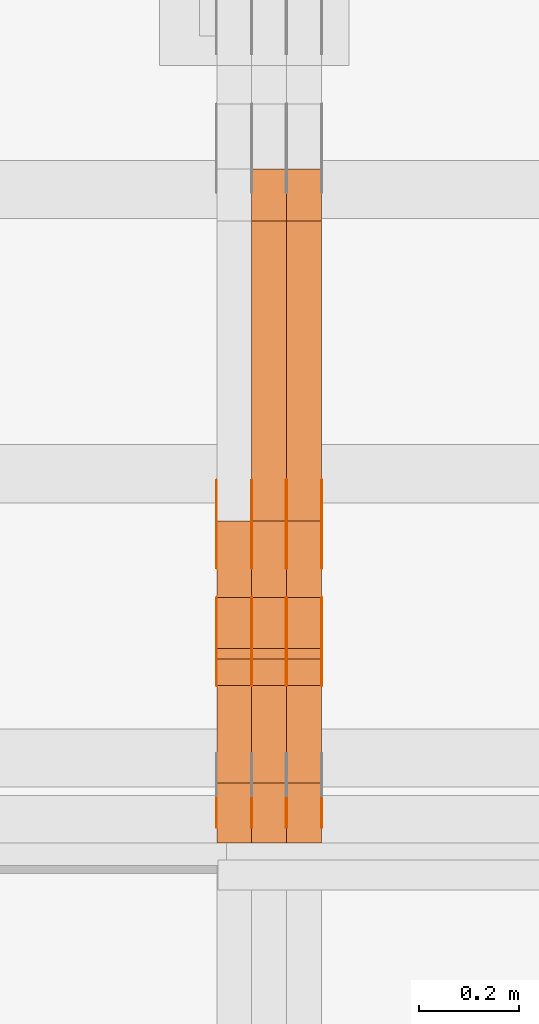
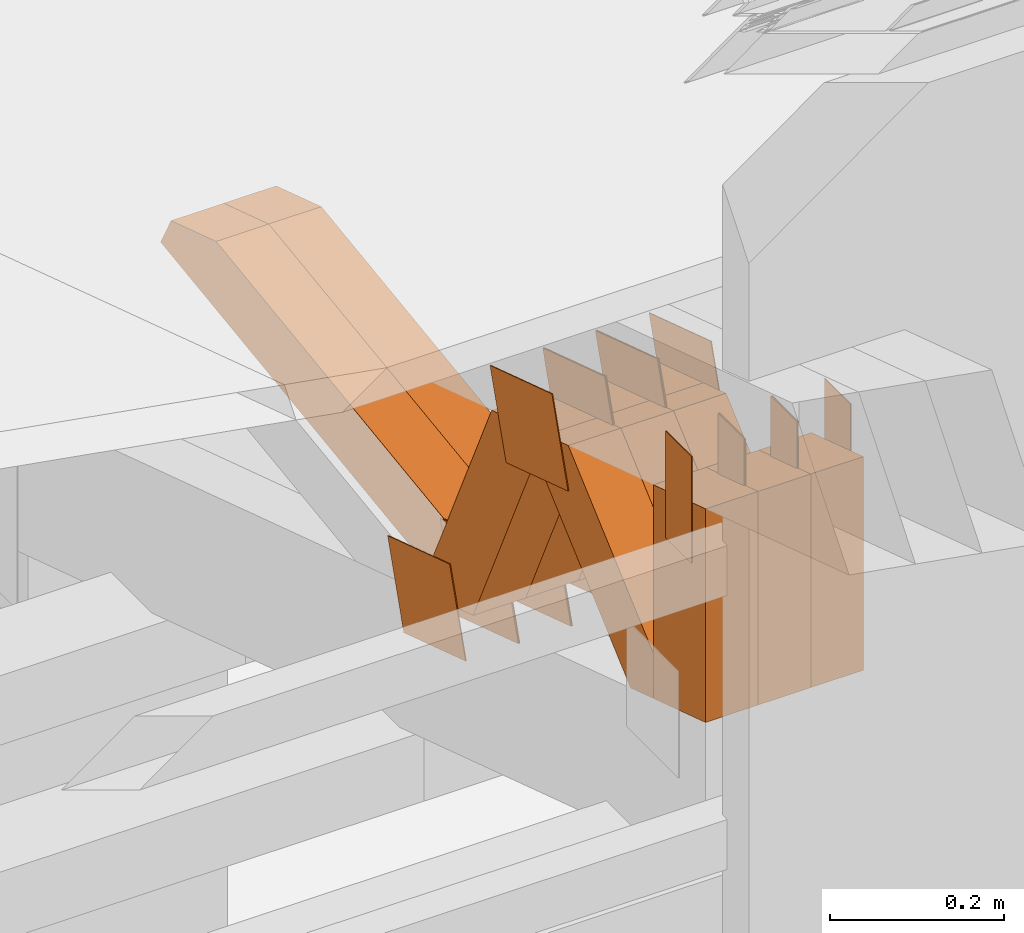
# One storey, part 290 of 385: 29 proxies.
"""IFC2X3 building model written with IfcOpenShell, lengths in millimetres."""

from ifc_helpers import new_model, entity, si_unit, converted_unit, derived_unit, direction, frame, origin, origin_2d_with_axis, place, context, subcontext, project, spatial, polyline, rectangle, outline, extrude, source, transform, mapped, material, type_object, type_shapes, element, save


model = new_model("IFC2X3")

# Units and contexts
model_context = context("Model", 3, precision=0.01, world=origin(), true_north=direction((6.12303176911189e-17, 1.0)))
body_context = subcontext(model_context, "Body", "Model", "MODEL_VIEW")
ifc_project = project(units=[si_unit("LENGTHUNIT", "METRE", prefix="MILLI"), si_unit("AREAUNIT", "SQUARE_METRE"), si_unit("VOLUMEUNIT", "CUBIC_METRE"), converted_unit("PLANEANGLEUNIT", "DEGREE", entity("IfcRatioMeasure", 0.0174532925199433), si_unit("PLANEANGLEUNIT", "RADIAN"), dimensions=[0, 0, 0, 0, 0, 0, 0]), si_unit("MASSUNIT", "GRAM", prefix="KILO"), derived_unit("MASSDENSITYUNIT", [(si_unit("MASSUNIT", "GRAM", prefix="KILO"), 1), (si_unit("LENGTHUNIT", "METRE"), -3)]), si_unit("TIMEUNIT", "SECOND"), si_unit("FREQUENCYUNIT", "HERTZ"), si_unit("THERMODYNAMICTEMPERATUREUNIT", "DEGREE_CELSIUS"), derived_unit("THERMALTRANSMITTANCEUNIT", [(si_unit("MASSUNIT", "GRAM", prefix="KILO"), 1), (si_unit("THERMODYNAMICTEMPERATUREUNIT", "KELVIN"), -1), (si_unit("TIMEUNIT", "SECOND"), -3)]), derived_unit("VOLUMETRICFLOWRATEUNIT", [(si_unit("LENGTHUNIT", "METRE"), 3), (si_unit("TIMEUNIT", "SECOND"), -1)]), si_unit("ELECTRICCURRENTUNIT", "AMPERE"), si_unit("ELECTRICVOLTAGEUNIT", "VOLT"), si_unit("POWERUNIT", "WATT"), si_unit("FORCEUNIT", "NEWTON", prefix="KILO"), si_unit("ILLUMINANCEUNIT", "LUX"), si_unit("LUMINOUSFLUXUNIT", "LUMEN"), si_unit("LUMINOUSINTENSITYUNIT", "CANDELA"), derived_unit("USERDEFINED", [(si_unit("MASSUNIT", "GRAM", prefix="KILO"), -1), (si_unit("LENGTHUNIT", "METRE"), -2), (si_unit("TIMEUNIT", "SECOND"), 3), (si_unit("LUMINOUSFLUXUNIT", "LUMEN"), 1)]), derived_unit("LINEARVELOCITYUNIT", [(si_unit("LENGTHUNIT", "METRE"), 1), (si_unit("TIMEUNIT", "SECOND"), -1)]), si_unit("PRESSUREUNIT", "PASCAL"), derived_unit("USERDEFINED", [(si_unit("LENGTHUNIT", "METRE"), -2), (si_unit("MASSUNIT", "GRAM", prefix="KILO"), 1), (si_unit("TIMEUNIT", "SECOND"), -2)])], contexts=[model_context])

# Site, building, storey
site_placement = place(None, origin())
site = spatial("IfcSite", under=ifc_project, at=site_placement, CompositionType="ELEMENT")
building_placement = place(site_placement, origin())
building = spatial("IfcBuilding", under=site, at=building_placement, CompositionType="ELEMENT")
storey_placement = place(building_placement, origin())
storey = spatial("IfcBuildingStorey", under=building, at=storey_placement, Name="Default", CompositionType="ELEMENT", Elevation=0.0)

# Proxies
ifc_material_1 = material(Name="IfcSurfaceStyle #480492")
building_element_proxy_type_1 = type_object("IfcBuildingElementProxyType", PredefinedType="NOTDEFINED", material=ifc_material_1)
shared_shape_1 = source(origin(), body_context, "Body", "SweptSolid", [
    extrude(outline(polyline([(-74.9998605591118, -59.9999264677601), (74.9998754286171, -59.9999264677601), (74.9998605591118, 59.9999264677602), (-74.9998754286171, 59.9999264677602), (-74.9998605591118, -59.9999264677601)])), frame((74.9998754286171, 60.0000503992849, 0.0), z_axis=(0.0, 0.0, 1.0), x_axis=(-1.0, 0.0, 0.0)), (0.0, 0.0, 1.0), 1.3),
])
type_shapes(building_element_proxy_type_1, [shared_shape_1])
proxy_1_placement = place(building_placement, frame((39386.3, 16352.8320303235, 3323.23212676408), z_axis=(-1.0, 0.0, 0.0), x_axis=(0.0, -0.951056516295124, 0.309016994375039)))
element("IfcBuildingElementProxy", 1, at=proxy_1_placement, inside=storey, type_object=building_element_proxy_type_1, material=ifc_material_1, context=body_context, shape_type="MappedRepresentation", body=[
    mapped(shared_shape_1, transform((0.0, 0.0, 0.0), scale=1.0)),
])
ifc_material_2 = material(Name="IfcSurfaceStyle #480435")
building_element_proxy_type_2 = type_object("IfcBuildingElementProxyType", PredefinedType="NOTDEFINED", material=ifc_material_2)
shared_shape_2 = source(origin(), body_context, "Body", "SweptSolid", [
    extrude(outline(polyline([(-74.9998605591118, -59.9999264677601), (74.9998754286171, -59.9999264677601), (74.9998605591118, 59.9999264677602), (-74.9998754286171, 59.9999264677602), (-74.9998605591118, -59.9999264677601)])), frame((74.9998754286171, 60.0000503992849, 0.0), z_axis=(0.0, 0.0, 1.0), x_axis=(-1.0, 0.0, 0.0)), (0.0, 0.0, 1.0), 1.3),
])
type_shapes(building_element_proxy_type_2, [shared_shape_2])
proxy_2_placement = place(building_placement, frame((39315.0, 16352.8320303235, 3323.23212676408), z_axis=(-1.0, 0.0, 0.0), x_axis=(0.0, -0.951056516295124, 0.309016994375039)))
element("IfcBuildingElementProxy", 2, at=proxy_2_placement, inside=storey, type_object=building_element_proxy_type_2, material=ifc_material_2, context=body_context, shape_type="MappedRepresentation", body=[
    mapped(shared_shape_2, transform((0.0, 0.0, 0.0), scale=1.0)),
])
ifc_material_3 = material(Name="IfcSurfaceStyle #480378")
building_element_proxy_type_3 = type_object("IfcBuildingElementProxyType", PredefinedType="NOTDEFINED", material=ifc_material_3)
shared_shape_3 = source(origin(), body_context, "Body", "SweptSolid", [
    extrude(outline(polyline([(-74.9998605591118, -59.9999264677601), (74.9998754286171, -59.9999264677601), (74.9998605591118, 59.9999264677602), (-74.9998754286171, 59.9999264677602), (-74.9998605591118, -59.9999264677601)])), frame((74.9998754286171, 60.0000503992849, 0.0), z_axis=(0.0, 0.0, 1.0), x_axis=(-1.0, 0.0, 0.0)), (0.0, 0.0, 1.0), 1.3),
])
type_shapes(building_element_proxy_type_3, [shared_shape_3])
proxy_3_placement = place(building_placement, frame((39316.3, 16352.8320303235, 3323.23212676408), z_axis=(-1.0, 0.0, 0.0), x_axis=(0.0, -0.951056516295124, 0.309016994375039)))
element("IfcBuildingElementProxy", 3, at=proxy_3_placement, inside=storey, type_object=building_element_proxy_type_3, material=ifc_material_3, context=body_context, shape_type="MappedRepresentation", body=[
    mapped(shared_shape_3, transform((0.0, 0.0, 0.0), scale=1.0)),
])
ifc_material_4 = material(Name="IfcSurfaceStyle #480321")
building_element_proxy_type_4 = type_object("IfcBuildingElementProxyType", PredefinedType="NOTDEFINED", material=ifc_material_4)
shared_shape_4 = source(origin(), body_context, "Body", "SweptSolid", [
    extrude(outline(polyline([(-74.9998605591118, -59.9999264677601), (74.9998754286171, -59.9999264677601), (74.9998605591118, 59.9999264677602), (-74.9998754286171, 59.9999264677602), (-74.9998605591118, -59.9999264677601)])), frame((74.9998754286171, 60.0000503992849, 0.0), z_axis=(0.0, 0.0, 1.0), x_axis=(-1.0, 0.0, 0.0)), (0.0, 0.0, 1.0), 1.29999999999999),
])
type_shapes(building_element_proxy_type_4, [shared_shape_4])
proxy_4_placement = place(building_placement, frame((39245.0, 16352.8320303235, 3323.23212676408), z_axis=(-1.0, 0.0, 0.0), x_axis=(0.0, -0.951056516295124, 0.309016994375039)))
element("IfcBuildingElementProxy", 4, at=proxy_4_placement, inside=storey, type_object=building_element_proxy_type_4, material=ifc_material_4, context=body_context, shape_type="MappedRepresentation", body=[
    mapped(shared_shape_4, transform((0.0, 0.0, 0.0), scale=1.0)),
])
ifc_material_5 = material(Name="IfcSurfaceStyle #480264")
building_element_proxy_type_5 = type_object("IfcBuildingElementProxyType", PredefinedType="NOTDEFINED", material=ifc_material_5)
shared_shape_5 = source(origin(), body_context, "Body", "SweptSolid", [
    extrude(outline(polyline([(-74.9998605591118, -59.9999264677601), (74.9998754286171, -59.9999264677601), (74.9998605591118, 59.9999264677602), (-74.9998754286171, 59.9999264677602), (-74.9998605591118, -59.9999264677601)])), frame((74.9998754286171, 60.0000503992849, 0.0), z_axis=(0.0, 0.0, 1.0), x_axis=(-1.0, 0.0, 0.0)), (0.0, 0.0, 1.0), 1.29999999999999),
])
type_shapes(building_element_proxy_type_5, [shared_shape_5])
proxy_5_placement = place(building_placement, frame((39246.3, 16352.8320303235, 3323.23212676408), z_axis=(-1.0, 0.0, 0.0), x_axis=(0.0, -0.951056516295124, 0.309016994375039)))
element("IfcBuildingElementProxy", 5, at=proxy_5_placement, inside=storey, type_object=building_element_proxy_type_5, material=ifc_material_5, context=body_context, shape_type="MappedRepresentation", body=[
    mapped(shared_shape_5, transform((0.0, 0.0, 0.0), scale=1.0)),
])
ifc_material_6 = material(Name="IfcSurfaceStyle #480207")
building_element_proxy_type_6 = type_object("IfcBuildingElementProxyType", PredefinedType="NOTDEFINED", material=ifc_material_6)
shared_shape_6 = source(origin(), body_context, "Body", "SweptSolid", [
    extrude(outline(polyline([(-74.9998605591118, -59.9999264677601), (74.9998754286171, -59.9999264677601), (74.9998605591118, 59.9999264677602), (-74.9998754286171, 59.9999264677602), (-74.9998605591118, -59.9999264677601)])), frame((74.9998754286171, 60.0000503992849, 0.0), z_axis=(0.0, 0.0, 1.0), x_axis=(-1.0, 0.0, 0.0)), (0.0, 0.0, 1.0), 1.29999999999999),
])
type_shapes(building_element_proxy_type_6, [shared_shape_6])
proxy_6_placement = place(building_placement, frame((39175.0, 16352.8320303235, 3323.23212676408), z_axis=(-1.0, 0.0, 0.0), x_axis=(0.0, -0.951056516295124, 0.309016994375039)))
element("IfcBuildingElementProxy", 6, at=proxy_6_placement, inside=storey, type_object=building_element_proxy_type_6, material=ifc_material_6, context=body_context, shape_type="MappedRepresentation", body=[
    mapped(shared_shape_6, transform((0.0, 0.0, 0.0), scale=1.0)),
])
ifc_material_7 = material(Name="IfcSurfaceStyle #476046")
building_element_proxy_type_7 = type_object("IfcBuildingElementProxyType", PredefinedType="NOTDEFINED", material=ifc_material_7)
shared_shape_7 = source(origin(), body_context, "Body", "SweptSolid", [
    extrude(outline(polyline([(-75.0003249421702, -60.0000773549573), (75.0003398116874, -60.0000773549573), (75.0003249421711, 60.0000773549573), (-75.0003398116883, 60.0000773549573), (-75.0003249421702, -60.0000773549573)])), frame((75.0003398116874, 60.0000773549573, 0.0), z_axis=(0.0, 0.0, 1.0), x_axis=(-1.0, 0.0, 0.0)), (0.0, 0.0, 1.0), 1.3),
])
type_shapes(building_element_proxy_type_7, [shared_shape_7])
proxy_7_placement = place(building_placement, frame((39386.3, 16117.0849050545, 3705.49074668796), z_axis=(-1.0, 0.0, 0.0), x_axis=(0.0, -0.951056516295154, 0.309016994374948)))
element("IfcBuildingElementProxy", 7, at=proxy_7_placement, inside=storey, type_object=building_element_proxy_type_7, material=ifc_material_7, context=body_context, shape_type="MappedRepresentation", body=[
    mapped(shared_shape_7, transform((0.0, 0.0, 0.0), scale=1.0)),
])
ifc_material_8 = material(Name="IfcSurfaceStyle #475989")
building_element_proxy_type_8 = type_object("IfcBuildingElementProxyType", PredefinedType="NOTDEFINED", material=ifc_material_8)
shared_shape_8 = source(origin(), body_context, "Body", "SweptSolid", [
    extrude(outline(polyline([(-75.0003249421702, -60.0000773549573), (75.0003398116874, -60.0000773549573), (75.0003249421711, 60.0000773549573), (-75.0003398116883, 60.0000773549573), (-75.0003249421702, -60.0000773549573)])), frame((75.0003398116874, 60.0000773549573, 0.0), z_axis=(0.0, 0.0, 1.0), x_axis=(-1.0, 0.0, 0.0)), (0.0, 0.0, 1.0), 1.3),
])
type_shapes(building_element_proxy_type_8, [shared_shape_8])
proxy_8_placement = place(building_placement, frame((39315.0, 16117.0849050545, 3705.49074668796), z_axis=(-1.0, 0.0, 0.0), x_axis=(0.0, -0.951056516295154, 0.309016994374948)))
element("IfcBuildingElementProxy", 8, at=proxy_8_placement, inside=storey, type_object=building_element_proxy_type_8, material=ifc_material_8, context=body_context, shape_type="MappedRepresentation", body=[
    mapped(shared_shape_8, transform((0.0, 0.0, 0.0), scale=1.0)),
])
ifc_material_9 = material(Name="IfcSurfaceStyle #475932")
building_element_proxy_type_9 = type_object("IfcBuildingElementProxyType", PredefinedType="NOTDEFINED", material=ifc_material_9)
shared_shape_9 = source(origin(), body_context, "Body", "SweptSolid", [
    extrude(outline(polyline([(-75.0003249421702, -60.0000773549573), (75.0003398116874, -60.0000773549573), (75.0003249421711, 60.0000773549573), (-75.0003398116883, 60.0000773549573), (-75.0003249421702, -60.0000773549573)])), frame((75.0003398116874, 60.0000773549573, 0.0), z_axis=(0.0, 0.0, 1.0), x_axis=(-1.0, 0.0, 0.0)), (0.0, 0.0, 1.0), 1.3),
])
type_shapes(building_element_proxy_type_9, [shared_shape_9])
proxy_9_placement = place(building_placement, frame((39316.3, 16117.0849050545, 3705.49074668796), z_axis=(-1.0, 0.0, 0.0), x_axis=(0.0, -0.951056516295154, 0.309016994374948)))
element("IfcBuildingElementProxy", 9, at=proxy_9_placement, inside=storey, type_object=building_element_proxy_type_9, material=ifc_material_9, context=body_context, shape_type="MappedRepresentation", body=[
    mapped(shared_shape_9, transform((0.0, 0.0, 0.0), scale=1.0)),
])
ifc_material_10 = material(Name="IfcSurfaceStyle #475875")
building_element_proxy_type_10 = type_object("IfcBuildingElementProxyType", PredefinedType="NOTDEFINED", material=ifc_material_10)
shared_shape_10 = source(origin(), body_context, "Body", "SweptSolid", [
    extrude(outline(polyline([(-75.0003249421702, -60.0000773549573), (75.0003398116874, -60.0000773549573), (75.0003249421711, 60.0000773549573), (-75.0003398116883, 60.0000773549573), (-75.0003249421702, -60.0000773549573)])), frame((75.0003398116874, 60.0000773549573, 0.0), z_axis=(0.0, 0.0, 1.0), x_axis=(-1.0, 0.0, 0.0)), (0.0, 0.0, 1.0), 1.29999999999999),
])
type_shapes(building_element_proxy_type_10, [shared_shape_10])
proxy_10_placement = place(building_placement, frame((39245.0, 16117.0849050545, 3705.49074668796), z_axis=(-1.0, 0.0, 0.0), x_axis=(0.0, -0.951056516295154, 0.309016994374948)))
element("IfcBuildingElementProxy", 10, at=proxy_10_placement, inside=storey, type_object=building_element_proxy_type_10, material=ifc_material_10, context=body_context, shape_type="MappedRepresentation", body=[
    mapped(shared_shape_10, transform((0.0, 0.0, 0.0), scale=1.0)),
])
ifc_material_11 = material(Name="IfcSurfaceStyle #475818")
building_element_proxy_type_11 = type_object("IfcBuildingElementProxyType", PredefinedType="NOTDEFINED", material=ifc_material_11)
shared_shape_11 = source(origin(), body_context, "Body", "SweptSolid", [
    extrude(outline(polyline([(-75.0003249421702, -60.0000773549573), (75.0003398116874, -60.0000773549573), (75.0003249421711, 60.0000773549573), (-75.0003398116883, 60.0000773549573), (-75.0003249421702, -60.0000773549573)])), frame((75.0003398116874, 60.0000773549573, 0.0), z_axis=(0.0, 0.0, 1.0), x_axis=(-1.0, 0.0, 0.0)), (0.0, 0.0, 1.0), 1.29999999999999),
])
type_shapes(building_element_proxy_type_11, [shared_shape_11])
proxy_11_placement = place(building_placement, frame((39246.3, 16117.0849050545, 3705.49074668796), z_axis=(-1.0, 0.0, 0.0), x_axis=(0.0, -0.951056516295154, 0.309016994374948)))
element("IfcBuildingElementProxy", 11, at=proxy_11_placement, inside=storey, type_object=building_element_proxy_type_11, material=ifc_material_11, context=body_context, shape_type="MappedRepresentation", body=[
    mapped(shared_shape_11, transform((0.0, 0.0, 0.0), scale=1.0)),
])
ifc_material_12 = material(Name="IfcSurfaceStyle #475761")
building_element_proxy_type_12 = type_object("IfcBuildingElementProxyType", PredefinedType="NOTDEFINED", material=ifc_material_12)
shared_shape_12 = source(origin(), body_context, "Body", "SweptSolid", [
    extrude(outline(polyline([(-75.0003249421702, -60.0000773549573), (75.0003398116874, -60.0000773549573), (75.0003249421711, 60.0000773549573), (-75.0003398116883, 60.0000773549573), (-75.0003249421702, -60.0000773549573)])), frame((75.0003398116874, 60.0000773549573, 0.0), z_axis=(0.0, 0.0, 1.0), x_axis=(-1.0, 0.0, 0.0)), (0.0, 0.0, 1.0), 1.29999999999999),
])
type_shapes(building_element_proxy_type_12, [shared_shape_12])
proxy_12_placement = place(building_placement, frame((39175.0, 16117.0849050545, 3705.49074668796), z_axis=(-1.0, 0.0, 0.0), x_axis=(0.0, -0.951056516295154, 0.309016994374948)))
element("IfcBuildingElementProxy", 12, at=proxy_12_placement, inside=storey, type_object=building_element_proxy_type_12, material=ifc_material_12, context=body_context, shape_type="MappedRepresentation", body=[
    mapped(shared_shape_12, transform((0.0, 0.0, 0.0), scale=1.0)),
])
ifc_material_13 = material(Name="IfcSurfaceStyle #475362")
building_element_proxy_type_13 = type_object("IfcBuildingElementProxyType", PredefinedType="NOTDEFINED", material=ifc_material_13)
shared_shape_13 = source(origin(), body_context, "Body", "SweptSolid", [
    extrude(rectangle(XDim=150.0, YDim=60.0, at=origin_2d_with_axis()), frame((75.0000705696311, 30.0, 0.0), z_axis=(0.0, 0.0, 1.0), x_axis=(-1.0, 0.0, 0.0)), (0.0, 0.0, 1.0), 1.3),
])
type_shapes(building_element_proxy_type_13, [shared_shape_13])
proxy_13_placement = place(building_placement, frame((39386.3, 15750.0, 3972.59919166338), z_axis=(-1.0, 0.0, 0.0), x_axis=(0.0, 0.0, -1.0)))
element("IfcBuildingElementProxy", 13, at=proxy_13_placement, inside=storey, type_object=building_element_proxy_type_13, material=ifc_material_13, context=body_context, shape_type="MappedRepresentation", body=[
    mapped(shared_shape_13, transform((0.0, 0.0, 0.0), scale=1.0)),
])
ifc_material_14 = material(Name="IfcSurfaceStyle #475305")
building_element_proxy_type_14 = type_object("IfcBuildingElementProxyType", PredefinedType="NOTDEFINED", material=ifc_material_14)
shared_shape_14 = source(origin(), body_context, "Body", "SweptSolid", [
    extrude(rectangle(XDim=150.0, YDim=60.0, at=origin_2d_with_axis()), frame((75.0000705696311, 30.0, 0.0), z_axis=(0.0, 0.0, 1.0), x_axis=(-1.0, 0.0, 0.0)), (0.0, 0.0, 1.0), 1.3),
])
type_shapes(building_element_proxy_type_14, [shared_shape_14])
proxy_14_placement = place(building_placement, frame((39315.0, 15750.0, 3972.59919166338), z_axis=(-1.0, 0.0, 0.0), x_axis=(0.0, 0.0, -1.0)))
element("IfcBuildingElementProxy", 14, at=proxy_14_placement, inside=storey, type_object=building_element_proxy_type_14, material=ifc_material_14, context=body_context, shape_type="MappedRepresentation", body=[
    mapped(shared_shape_14, transform((0.0, 0.0, 0.0), scale=1.0)),
])
ifc_material_15 = material(Name="IfcSurfaceStyle #475248")
building_element_proxy_type_15 = type_object("IfcBuildingElementProxyType", PredefinedType="NOTDEFINED", material=ifc_material_15)
shared_shape_15 = source(origin(), body_context, "Body", "SweptSolid", [
    extrude(rectangle(XDim=150.0, YDim=60.0, at=origin_2d_with_axis()), frame((75.0000705696311, 30.0, 0.0), z_axis=(0.0, 0.0, 1.0), x_axis=(-1.0, 0.0, 0.0)), (0.0, 0.0, 1.0), 1.3),
])
type_shapes(building_element_proxy_type_15, [shared_shape_15])
proxy_15_placement = place(building_placement, frame((39316.3, 15750.0, 3972.59919166338), z_axis=(-1.0, 0.0, 0.0), x_axis=(0.0, 0.0, -1.0)))
element("IfcBuildingElementProxy", 15, at=proxy_15_placement, inside=storey, type_object=building_element_proxy_type_15, material=ifc_material_15, context=body_context, shape_type="MappedRepresentation", body=[
    mapped(shared_shape_15, transform((0.0, 0.0, 0.0), scale=1.0)),
])
ifc_material_16 = material(Name="IfcSurfaceStyle #475191")
building_element_proxy_type_16 = type_object("IfcBuildingElementProxyType", PredefinedType="NOTDEFINED", material=ifc_material_16)
shared_shape_16 = source(origin(), body_context, "Body", "SweptSolid", [
    extrude(rectangle(XDim=150.0, YDim=60.0, at=origin_2d_with_axis()), frame((75.0000705696311, 30.0, 0.0), z_axis=(0.0, 0.0, 1.0), x_axis=(-1.0, 0.0, 0.0)), (0.0, 0.0, 1.0), 1.29999999999999),
])
type_shapes(building_element_proxy_type_16, [shared_shape_16])
proxy_16_placement = place(building_placement, frame((39245.0, 15750.0, 3972.59919166338), z_axis=(-1.0, 0.0, 0.0), x_axis=(0.0, 0.0, -1.0)))
element("IfcBuildingElementProxy", 16, at=proxy_16_placement, inside=storey, type_object=building_element_proxy_type_16, material=ifc_material_16, context=body_context, shape_type="MappedRepresentation", body=[
    mapped(shared_shape_16, transform((0.0, 0.0, 0.0), scale=1.0)),
])
ifc_material_17 = material(Name="IfcSurfaceStyle #475134")
building_element_proxy_type_17 = type_object("IfcBuildingElementProxyType", PredefinedType="NOTDEFINED", material=ifc_material_17)
shared_shape_17 = source(origin(), body_context, "Body", "SweptSolid", [
    extrude(rectangle(XDim=150.0, YDim=60.0, at=origin_2d_with_axis()), frame((75.0000705696311, 30.0, 0.0), z_axis=(0.0, 0.0, 1.0), x_axis=(-1.0, 0.0, 0.0)), (0.0, 0.0, 1.0), 1.29999999999999),
])
type_shapes(building_element_proxy_type_17, [shared_shape_17])
proxy_17_placement = place(building_placement, frame((39246.3, 15750.0, 3972.59919166338), z_axis=(-1.0, 0.0, 0.0), x_axis=(0.0, 0.0, -1.0)))
element("IfcBuildingElementProxy", 17, at=proxy_17_placement, inside=storey, type_object=building_element_proxy_type_17, material=ifc_material_17, context=body_context, shape_type="MappedRepresentation", body=[
    mapped(shared_shape_17, transform((0.0, 0.0, 0.0), scale=1.0)),
])
ifc_material_18 = material(Name="IfcSurfaceStyle #475077")
building_element_proxy_type_18 = type_object("IfcBuildingElementProxyType", PredefinedType="NOTDEFINED", material=ifc_material_18)
shared_shape_18 = source(origin(), body_context, "Body", "SweptSolid", [
    extrude(rectangle(XDim=150.0, YDim=60.0, at=origin_2d_with_axis()), frame((75.0000705696311, 30.0, 0.0), z_axis=(0.0, 0.0, 1.0), x_axis=(-1.0, 0.0, 0.0)), (0.0, 0.0, 1.0), 1.29999999999999),
])
type_shapes(building_element_proxy_type_18, [shared_shape_18])
proxy_18_placement = place(building_placement, frame((39175.0, 15750.0, 3972.59919166338), z_axis=(-1.0, 0.0, 0.0), x_axis=(0.0, 0.0, -1.0)))
element("IfcBuildingElementProxy", 18, at=proxy_18_placement, inside=storey, type_object=building_element_proxy_type_18, material=ifc_material_18, context=body_context, shape_type="MappedRepresentation", body=[
    mapped(shared_shape_18, transform((0.0, 0.0, 0.0), scale=1.0)),
])
ifc_material_19 = material(Name="IfcSurfaceStyle #465993")
building_element_proxy_type_19 = type_object("IfcBuildingElementProxyType", Name="T1-W50 465991", PredefinedType="NOTDEFINED", material=ifc_material_19)
shared_shape_19 = source(origin(), body_context, "Body", "SweptSolid", [
    extrude(outline(polyline([(-128.56619634284, -47.4999385885712), (133.151257249084, -47.4999385885712), (161.172800006526, -0.000129729183733609), (147.291467726413, 47.500068317755), (-142.513973767368, 47.500068317755), (-170.535354871815, -0.000129729183754689), (-128.56619634284, -47.4999385885712)])), frame((161.17310141218, 47.5001898716564, 0.0), z_axis=(0.0, 0.0, 1.0), x_axis=(-1.0, 0.0, 0.0)), (0.0, 0.0, 1.0), 70.0),
])
type_shapes(building_element_proxy_type_19, [shared_shape_19])
proxy_19_placement = place(building_placement, frame((39385.0, 16060.0297689714, 3761.73994820667), z_axis=(-1.0, 0.0, 0.0), x_axis=(0.0, -0.749388407538668, -0.662130662820156)))
element("IfcBuildingElementProxy", 19, at=proxy_19_placement, inside=storey, type_object=building_element_proxy_type_19, material=ifc_material_19, Name="T1-W50", context=body_context, shape_type="MappedRepresentation", body=[
    mapped(shared_shape_19, transform((0.0, 0.0, 0.0), scale=1.0)),
])
ifc_material_20 = material(Name="IfcSurfaceStyle #465918")
building_element_proxy_type_20 = type_object("IfcBuildingElementProxyType", Name="T1-W50 465916", PredefinedType="NOTDEFINED", material=ifc_material_20)
shared_shape_20 = source(origin(), body_context, "Body", "SweptSolid", [
    extrude(outline(polyline([(-128.56619634284, -47.4999385885712), (133.151257249084, -47.4999385885712), (161.172800006526, -0.000129729183733609), (147.291467726413, 47.500068317755), (-142.513973767368, 47.500068317755), (-170.535354871815, -0.000129729183754689), (-128.56619634284, -47.4999385885712)])), frame((161.17310141218, 47.5001898716564, 0.0), z_axis=(0.0, 0.0, 1.0), x_axis=(-1.0, 0.0, 0.0)), (0.0, 0.0, 1.0), 70.0),
])
type_shapes(building_element_proxy_type_20, [shared_shape_20])
proxy_20_placement = place(building_placement, frame((39315.0, 16060.0297689714, 3761.73994820667), z_axis=(-1.0, 0.0, 0.0), x_axis=(0.0, -0.749388407538668, -0.662130662820156)))
element("IfcBuildingElementProxy", 20, at=proxy_20_placement, inside=storey, type_object=building_element_proxy_type_20, material=ifc_material_20, Name="T1-W50", context=body_context, shape_type="MappedRepresentation", body=[
    mapped(shared_shape_20, transform((0.0, 0.0, 0.0), scale=1.0)),
])
ifc_material_21 = material(Name="IfcSurfaceStyle #465843")
building_element_proxy_type_21 = type_object("IfcBuildingElementProxyType", Name="T1-W50 465841", PredefinedType="NOTDEFINED", material=ifc_material_21)
shared_shape_21 = source(origin(), body_context, "Body", "SweptSolid", [
    extrude(outline(polyline([(-128.56619634284, -47.4999385885712), (133.151257249084, -47.4999385885712), (161.172800006526, -0.000129729183733609), (147.291467726413, 47.500068317755), (-142.513973767368, 47.500068317755), (-170.535354871815, -0.000129729183754689), (-128.56619634284, -47.4999385885712)])), frame((161.17310141218, 47.5001898716564, 0.0), z_axis=(0.0, 0.0, 1.0), x_axis=(-1.0, 0.0, 0.0)), (0.0, 0.0, 1.0), 70.0),
])
type_shapes(building_element_proxy_type_21, [shared_shape_21])
proxy_21_placement = place(building_placement, frame((39245.0, 16060.0297689714, 3761.73994820667), z_axis=(-1.0, 0.0, 0.0), x_axis=(0.0, -0.749388407538668, -0.662130662820156)))
element("IfcBuildingElementProxy", 21, at=proxy_21_placement, inside=storey, type_object=building_element_proxy_type_21, material=ifc_material_21, Name="T1-W50", context=body_context, shape_type="MappedRepresentation", body=[
    mapped(shared_shape_21, transform((0.0, 0.0, 0.0), scale=1.0)),
])
ifc_material_22 = material(Name="IfcSurfaceStyle #465597")
building_element_proxy_type_22 = type_object("IfcBuildingElementProxyType", Name="T1-W2 465595", PredefinedType="NOTDEFINED", material=ifc_material_22)
shared_shape_22 = source(origin(), body_context, "Body", "SweptSolid", [
    extrude(outline(polyline([(-130.705993652344, -60.0), (169.696350097656, -60.0), (130.706115722656, 60.0), (-169.696472167969, 60.0), (-130.705993652344, -60.0)])), frame((169.696429629256, 60.0, 0.0), z_axis=(0.0, 0.0, 1.0), x_axis=(-1.0, 0.0, 0.0)), (0.0, 0.0, 1.0), 70.0),
])
type_shapes(building_element_proxy_type_22, [shared_shape_22])
proxy_22_placement = place(building_placement, frame((39385.0, 15660.0, 3577.70158062465), z_axis=(-1.0, 0.0, 0.0), x_axis=(0.0, 0.0, 1.0)))
element("IfcBuildingElementProxy", 22, at=proxy_22_placement, inside=storey, type_object=building_element_proxy_type_22, material=ifc_material_22, Name="T1-W2", context=body_context, shape_type="MappedRepresentation", body=[
    mapped(shared_shape_22, transform((0.0, 0.0, 0.0), scale=1.0)),
])
ifc_material_23 = material(Name="IfcSurfaceStyle #465540")
building_element_proxy_type_23 = type_object("IfcBuildingElementProxyType", Name="T1-W2 465538", PredefinedType="NOTDEFINED", material=ifc_material_23)
shared_shape_23 = source(origin(), body_context, "Body", "SweptSolid", [
    extrude(outline(polyline([(-130.705993652344, -60.0), (169.696350097656, -60.0), (130.706115722656, 60.0), (-169.696472167969, 60.0), (-130.705993652344, -60.0)])), frame((169.696429629256, 60.0, 0.0), z_axis=(0.0, 0.0, 1.0), x_axis=(-1.0, 0.0, 0.0)), (0.0, 0.0, 1.0), 70.0),
])
type_shapes(building_element_proxy_type_23, [shared_shape_23])
proxy_23_placement = place(building_placement, frame((39315.0, 15660.0, 3577.70158062465), z_axis=(-1.0, 0.0, 0.0), x_axis=(0.0, 0.0, 1.0)))
element("IfcBuildingElementProxy", 23, at=proxy_23_placement, inside=storey, type_object=building_element_proxy_type_23, material=ifc_material_23, Name="T1-W2", context=body_context, shape_type="MappedRepresentation", body=[
    mapped(shared_shape_23, transform((0.0, 0.0, 0.0), scale=1.0)),
])
ifc_material_24 = material(Name="IfcSurfaceStyle #465483")
building_element_proxy_type_24 = type_object("IfcBuildingElementProxyType", Name="T1-W2 465481", PredefinedType="NOTDEFINED", material=ifc_material_24)
shared_shape_24 = source(origin(), body_context, "Body", "SweptSolid", [
    extrude(outline(polyline([(-130.705993652344, -60.0), (169.696350097656, -60.0), (130.706115722656, 60.0), (-169.696472167969, 60.0), (-130.705993652344, -60.0)])), frame((169.696429629256, 60.0, 0.0), z_axis=(0.0, 0.0, 1.0), x_axis=(-1.0, 0.0, 0.0)), (0.0, 0.0, 1.0), 70.0),
])
type_shapes(building_element_proxy_type_24, [shared_shape_24])
proxy_24_placement = place(building_placement, frame((39245.0, 15660.0, 3577.70158062465), z_axis=(-1.0, 0.0, 0.0), x_axis=(0.0, 0.0, 1.0)))
element("IfcBuildingElementProxy", 24, at=proxy_24_placement, inside=storey, type_object=building_element_proxy_type_24, material=ifc_material_24, Name="T1-W2", context=body_context, shape_type="MappedRepresentation", body=[
    mapped(shared_shape_24, transform((0.0, 0.0, 0.0), scale=1.0)),
])
ifc_material_25 = material(Name="IfcSurfaceStyle #465426")
building_element_proxy_type_25 = type_object("IfcBuildingElementProxyType", Name="T1-W44 465424", PredefinedType="NOTDEFINED", material=ifc_material_25)
shared_shape_25 = source(origin(), body_context, "Body", "SweptSolid", [
    extrude(outline(polyline([(-184.551057772692, -47.4997984945814), (177.527112951531, -47.4997984945814), (162.630077773546, -0.000452497529500495), (118.068221667048, 47.5000247433462), (-273.674354619433, 47.5000247433462), (-184.551057772692, -47.4997984945814)])), frame((177.527112951531, 47.5002721629815, 0.0), z_axis=(0.0, 0.0, 1.0), x_axis=(-1.0, 0.0, 0.0)), (0.0, 0.0, 1.0), 70.0),
])
type_shapes(building_element_proxy_type_25, [shared_shape_25])
proxy_25_placement = place(building_placement, frame((39385.0, 16220.4899216004, 3388.98238154171), z_axis=(-1.0, 0.0, 0.0), x_axis=(0.0, -0.425335045192995, 0.905035965766374)))
element("IfcBuildingElementProxy", 25, at=proxy_25_placement, inside=storey, type_object=building_element_proxy_type_25, material=ifc_material_25, Name="T1-W44", context=body_context, shape_type="MappedRepresentation", body=[
    mapped(shared_shape_25, transform((0.0, 0.0, 0.0), scale=1.0)),
])
ifc_material_26 = material(Name="IfcSurfaceStyle #465360")
building_element_proxy_type_26 = type_object("IfcBuildingElementProxyType", Name="T1-W44 465358", PredefinedType="NOTDEFINED", material=ifc_material_26)
shared_shape_26 = source(origin(), body_context, "Body", "SweptSolid", [
    extrude(outline(polyline([(-184.551057772692, -47.4997984945814), (177.527112951531, -47.4997984945814), (162.630077773546, -0.000452497529500495), (118.068221667048, 47.5000247433462), (-273.674354619433, 47.5000247433462), (-184.551057772692, -47.4997984945814)])), frame((177.527112951531, 47.5002721629815, 0.0), z_axis=(0.0, 0.0, 1.0), x_axis=(-1.0, 0.0, 0.0)), (0.0, 0.0, 1.0), 70.0),
])
type_shapes(building_element_proxy_type_26, [shared_shape_26])
proxy_26_placement = place(building_placement, frame((39315.0, 16220.4899216004, 3388.98238154171), z_axis=(-1.0, 0.0, 0.0), x_axis=(0.0, -0.425335045192995, 0.905035965766374)))
element("IfcBuildingElementProxy", 26, at=proxy_26_placement, inside=storey, type_object=building_element_proxy_type_26, material=ifc_material_26, Name="T1-W44", context=body_context, shape_type="MappedRepresentation", body=[
    mapped(shared_shape_26, transform((0.0, 0.0, 0.0), scale=1.0)),
])
ifc_material_27 = material(Name="IfcSurfaceStyle #465294")
building_element_proxy_type_27 = type_object("IfcBuildingElementProxyType", Name="T1-W44 465292", PredefinedType="NOTDEFINED", material=ifc_material_27)
shared_shape_27 = source(origin(), body_context, "Body", "SweptSolid", [
    extrude(outline(polyline([(-184.551057772692, -47.4997984945814), (177.527112951531, -47.4997984945814), (162.630077773546, -0.000452497529500495), (118.068221667048, 47.5000247433462), (-273.674354619433, 47.5000247433462), (-184.551057772692, -47.4997984945814)])), frame((177.527112951531, 47.5002721629815, 0.0), z_axis=(0.0, 0.0, 1.0), x_axis=(-1.0, 0.0, 0.0)), (0.0, 0.0, 1.0), 70.0),
])
type_shapes(building_element_proxy_type_27, [shared_shape_27])
proxy_27_placement = place(building_placement, frame((39245.0, 16220.4899216004, 3388.98238154171), z_axis=(-1.0, 0.0, 0.0), x_axis=(0.0, -0.425335045192995, 0.905035965766374)))
element("IfcBuildingElementProxy", 27, at=proxy_27_placement, inside=storey, type_object=building_element_proxy_type_27, material=ifc_material_27, Name="T1-W44", context=body_context, shape_type="MappedRepresentation", body=[
    mapped(shared_shape_27, transform((0.0, 0.0, 0.0), scale=1.0)),
])
ifc_material_28 = material(Name="IfcSurfaceStyle #465030")
building_element_proxy_type_28 = type_object("IfcBuildingElementProxyType", Name="T1-W8 465028", PredefinedType="NOTDEFINED", material=ifc_material_28)
shared_shape_28 = source(origin(), body_context, "Body", "SweptSolid", [
    extrude(outline(polyline([(-476.725263324644, -47.5001051695965), (180.672765845439, -47.5001051695965), (279.11020091716, -1.03605560390907e-06), (296.793624402619, 47.5001056876243), (-279.851327840575, 47.5001056876243), (-476.725263324644, -47.5001051695965)])), frame((296.793624402619, 47.5001056876243, 0.0), z_axis=(0.0, 0.0, 1.0), x_axis=(-1.0, 0.0, 0.0)), (0.0, 0.0, 1.0), 70.0),
])
type_shapes(building_element_proxy_type_28, [shared_shape_28])
proxy_28_placement = place(building_placement, frame((39385.0, 17036.40625, 3432.97192382813), z_axis=(-1.0, 0.0, 0.0), x_axis=(0.0, -0.990844046556832, -0.135011389900564)))
element("IfcBuildingElementProxy", 28, at=proxy_28_placement, inside=storey, type_object=building_element_proxy_type_28, material=ifc_material_28, Name="T1-W8", context=body_context, shape_type="MappedRepresentation", body=[
    mapped(shared_shape_28, transform((0.0, 0.0, 0.0), scale=1.0)),
])
ifc_material_29 = material(Name="IfcSurfaceStyle #464964")
building_element_proxy_type_29 = type_object("IfcBuildingElementProxyType", Name="T1-W8 464962", PredefinedType="NOTDEFINED", material=ifc_material_29)
shared_shape_29 = source(origin(), body_context, "Body", "SweptSolid", [
    extrude(outline(polyline([(-476.725263324644, -47.5001051695965), (180.672765845439, -47.5001051695965), (279.11020091716, -1.03605560390907e-06), (296.793624402619, 47.5001056876243), (-279.851327840575, 47.5001056876243), (-476.725263324644, -47.5001051695965)])), frame((296.793624402619, 47.5001056876243, 0.0), z_axis=(0.0, 0.0, 1.0), x_axis=(-1.0, 0.0, 0.0)), (0.0, 0.0, 1.0), 70.0),
])
type_shapes(building_element_proxy_type_29, [shared_shape_29])
proxy_29_placement = place(building_placement, frame((39315.0, 17036.40625, 3432.97192382813), z_axis=(-1.0, 0.0, 0.0), x_axis=(0.0, -0.990844046556832, -0.135011389900564)))
element("IfcBuildingElementProxy", 29, at=proxy_29_placement, inside=storey, type_object=building_element_proxy_type_29, material=ifc_material_29, Name="T1-W8", context=body_context, shape_type="MappedRepresentation", body=[
    mapped(shared_shape_29, transform((0.0, 0.0, 0.0), scale=1.0)),
])

save(model, "model.ifc")
